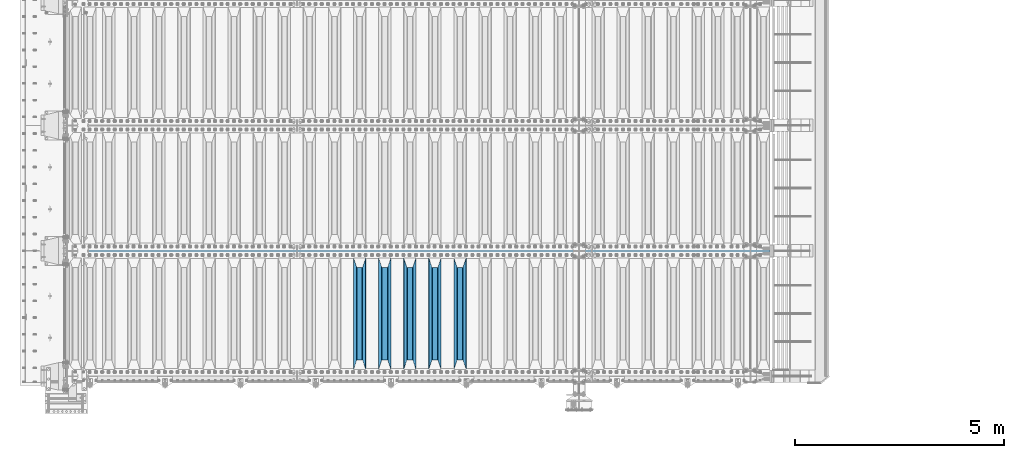
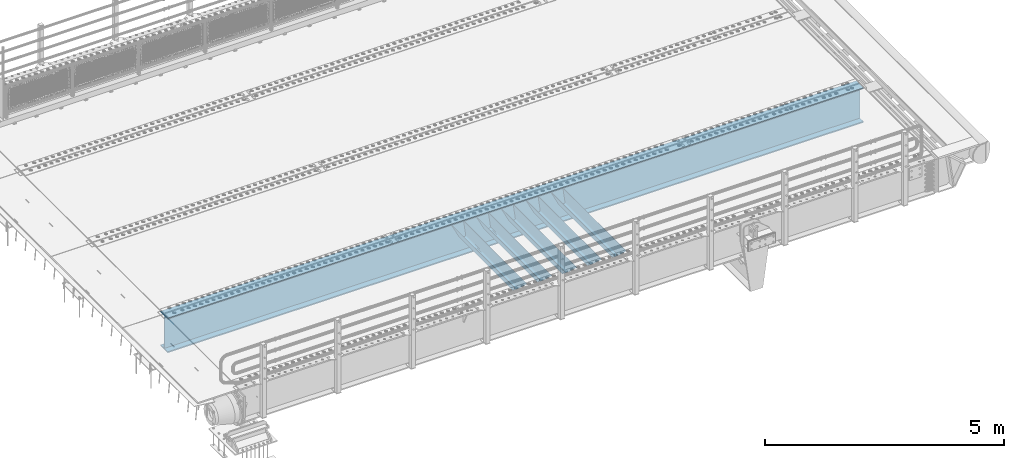
# One storey, part 107 of 257: 6 beams.
"""IFC2X3 building model written with IfcOpenShell, lengths in millimetres."""

from ifc_helpers import new_model, si_unit, frame, origin_with_axes, place, context, subcontext, project, spatial, faceted_brep, material, type_object, element, save


model = new_model("IFC2X3")

# Units and contexts
model_context = context("Model", 3, precision=1e-05, world=origin_with_axes())
body_context = subcontext(model_context, "Body", "Model", "MODEL_VIEW")
ifc_project = project(units=[si_unit("LENGTHUNIT", "METRE", prefix="MILLI"), si_unit("AREAUNIT", "SQUARE_METRE"), si_unit("VOLUMEUNIT", "CUBIC_METRE"), si_unit("MASSUNIT", "GRAM", prefix="KILO"), si_unit("TIMEUNIT", "SECOND"), si_unit("PLANEANGLEUNIT", "RADIAN"), si_unit("SOLIDANGLEUNIT", "STERADIAN"), si_unit("THERMODYNAMICTEMPERATUREUNIT", "DEGREE_CELSIUS"), si_unit("LUMINOUSINTENSITYUNIT", "LUMEN")], contexts=[model_context])

# Site, building, storey
site_placement = place(None, origin_with_axes())
site = spatial("IfcSite", under=ifc_project, at=site_placement, CompositionType="ELEMENT")
building_placement = place(site_placement, origin_with_axes())
building = spatial("IfcBuilding", under=site, at=building_placement, Name="Standard", CompositionType="ELEMENT")
storey_placement = place(building_placement, origin_with_axes())
storey = spatial("IfcBuildingStorey", under=building, at=storey_placement, Name="Undefined", CompositionType="ELEMENT", Elevation=0.0)

# Beams
ifc_material = material(Name="STEEL/S355N")
beam_type_1 = type_object("IfcBeamType", PredefinedType="NOTDEFINED")
beam_1_placement = place(storey_placement, frame((51850.0, 175.0, -115.0), z_axis=(0.0, 0.0, 1.0), x_axis=(0.0, 1.0, 0.0)))
element("IfcBeam", 1, at=beam_1_placement, inside=storey, type_object=beam_type_1, material=ifc_material, context=body_context, shape_type="Brep", body=[
    faceted_brep([(0.0, 150.0, 115.0), (0.0, 143.690000000002, 115.0), (2650.00000000297, 143.690000000002, 115.0), (2650.00000000297, 150.0, 115.0), (2650.00000000297, 142.059565218406, 110.0000000031), (2650.00000000297, 148.369565218403, 110.0000000031), (2441.90079219208, -80.1103600731149, -98.0992078077845), (2437.7588105432, -77.5672621345584, -102.241189456673), (2434.06523489746, -74.4080125315522, -105.934765102404), (2430.91086095089, -70.7102721255724, -109.089139048974), (2428.37322971128, -66.5649389910031, -111.626770288588), (2426.51472138055, -62.0739139532889, -113.485278619323), (2425.38102192091, -57.3475956567636, -114.618978078955), (2424.99999999987, -52.5021667386536, -115.0), (2424.99999999987, 52.5021667386536, -115.0), (2425.38102192091, 57.3475956567636, -114.618978078955), (2426.51472138055, 62.0739139532889, -113.485278619323), (2428.37322971128, 66.5649389910031, -111.626770288588), (2430.91086095089, 70.7102721255724, -109.089139048974), (2434.06523489746, 74.4080125315522, -105.934765102404), (2437.7588105432, 77.5672621345584, -102.241189456673), (2441.90079219208, 80.1103600731149, -98.0992078077846), (2446.38936140511, 81.9747917625791, -93.6106385947584), (2448.24948500409, 76.2713538057287, -91.7505149957729), (2444.62967112262, 74.76777986261, -95.3703288772456), (2441.28936334126, 72.7168944282894, -98.710636658607), (2438.31067330438, 70.1691124903809, -101.689326695487), (2435.76682334747, 67.1870637758839, -104.233176652398), (2433.72034654133, 63.8440531834931, -106.279653458539), (2432.22154950041, 60.2222587982324, -107.778450499454), (2431.30727574265, 56.4107117849126, -108.692724257221), (2430.99999999987, 52.5031078186876, -109.0), (2430.99999999987, -52.5031078186876, -109.0), (2431.30727574265, -56.4107117849126, -108.692724257221), (2432.22154950041, -60.2222587982324, -107.778450499454), (2433.72034654133, -63.8440531834931, -106.279653458539), (2435.76682334747, -67.1870637758839, -104.233176652398), (2438.31067330438, -70.1691124903809, -101.689326695487), (2441.28936334126, -72.7168944282894, -98.7106366586071), (2444.62967112262, -74.76777986261, -95.3703288772457), (2448.24948500409, -76.2713538057287, -91.7505149957729), (2650.00000000297, -142.059565218406, 110.0000000031), (2650.00000000297, -148.369565218403, 110.0000000031), (2446.38936140511, -81.9747917625791, -93.6106385947584), (2650.00000000297, -143.690000000002, 115.0), (2650.00000000297, -150.0, 115.0), (0.0, -143.690000000002, 115.0), (0.0, -150.0, 115.0), (0.0, -148.369565218258, 110.000000002662), (203.61063859742, -81.9747917625791, -93.6106385947584), (208.099207810447, -80.1103600731149, -98.0992078077845), (212.241189459335, -77.5672621345584, -102.241189456673), (215.934765105066, -74.4080125315522, -105.934765102404), (219.089139051636, -70.7102721255724, -109.089139048974), (221.626770291251, -66.5649389910031, -111.626770288588), (223.485278621985, -62.0739139532889, -113.485278619323), (224.618978081617, -57.3475956567636, -114.618978078955), (225.000000002662, -52.5021667386536, -115.0), (225.000000002662, 52.5021667386536, -115.0), (224.618978081617, 57.3475956567636, -114.618978078955), (223.485278621985, 62.0739139532889, -113.485278619323), (221.626770291251, 66.5649389910031, -111.626770288588), (219.089139051636, 70.7102721255724, -109.089139048974), (215.934765105066, 74.4080125315522, -105.934765102404), (212.241189459335, 77.5672621345584, -102.241189456673), (208.099207810447, 80.1103600731149, -98.0992078077846), (203.61063859742, 81.9747917625791, -93.6106385947584), (0.0, 148.369565218258, 110.000000002662), (0.0, 142.05956521826, 110.000000002662), (201.750514998435, 76.2713538057287, -91.7505149957729), (205.370328879908, 74.76777986261, -95.3703288772456), (208.710636661269, 72.7168944282894, -98.710636658607), (211.689326698149, 70.1691124903809, -101.689326695487), (214.233176655061, 67.1870637758839, -104.233176652398), (216.279653461201, 63.8440531834931, -106.279653458539), (217.778450502116, 60.2222587982324, -107.778450499454), (218.692724259884, 56.4107117849126, -108.692724257221), (219.000000002662, 52.5031078186876, -109.0), (219.000000002662, -52.5031078186876, -109.0), (218.692724259884, -56.4107117849126, -108.692724257221), (217.778450502116, -60.2222587982324, -107.778450499454), (216.279653461201, -63.8440531834931, -106.279653458539), (214.233176655061, -67.1870637758839, -104.233176652398), (211.689326698149, -70.1691124903809, -101.689326695487), (208.710636661269, -72.7168944282894, -98.7106366586071), (205.370328879908, -74.76777986261, -95.3703288772457), (201.750514998435, -76.2713538057287, -91.7505149957729), (0.0, -142.05956521826, 110.000000002662)], [[[0, 1, 2, 3]], [[3, 2, 4, 5]], [[6, 7, 8, 9, 10, 11, 12, 13, 14, 15, 16, 17, 18, 19, 20, 21, 22, 5, 4, 23, 24, 25, 26, 27, 28, 29, 30, 31, 32, 33, 34, 35, 36, 37, 38, 39, 40, 41, 42, 43]], [[44, 45, 42, 41]], [[46, 47, 45, 44]], [[43, 42, 45, 47, 48, 49]], [[6, 43, 49, 50]], [[7, 6, 50, 51]], [[8, 7, 51, 52]], [[9, 8, 52, 53]], [[10, 9, 53, 54]], [[11, 10, 54, 55]], [[12, 11, 55, 56]], [[13, 12, 56, 57]], [[14, 13, 57, 58]], [[15, 14, 58, 59]], [[16, 15, 59, 60]], [[17, 16, 60, 61]], [[18, 17, 61, 62]], [[19, 18, 62, 63]], [[20, 19, 63, 64]], [[21, 20, 64, 65]], [[22, 21, 65, 66]], [[0, 3, 5, 22, 66, 67]], [[1, 0, 67, 68]], [[23, 4, 2, 1, 68, 69]], [[24, 23, 69, 70]], [[25, 24, 70, 71]], [[26, 25, 71, 72]], [[27, 26, 72, 73]], [[28, 27, 73, 74]], [[29, 28, 74, 75]], [[30, 29, 75, 76]], [[31, 30, 76, 77]], [[32, 31, 77, 78]], [[33, 32, 78, 79]], [[34, 33, 79, 80]], [[35, 34, 80, 81]], [[36, 35, 81, 82]], [[37, 36, 82, 83]], [[38, 37, 83, 84]], [[39, 38, 84, 85]], [[40, 39, 85, 86]], [[46, 44, 41, 40, 86, 87]], [[47, 46, 87, 48]], [[86, 85, 84, 83, 82, 81, 80, 79, 78, 77, 76, 75, 74, 73, 72, 71, 70, 69, 68, 67, 66, 65, 64, 63, 62, 61, 60, 59, 58, 57, 56, 55, 54, 53, 52, 51, 50, 49, 48, 87]]]),
])
beam_2_placement = place(storey_placement, frame((51250.0, 175.0, -115.0), z_axis=(0.0, 0.0, 1.0), x_axis=(0.0, 1.0, 0.0)))
element("IfcBeam", 2, at=beam_2_placement, inside=storey, type_object=beam_type_1, material=ifc_material, context=body_context, shape_type="Brep", body=[
    faceted_brep([(0.0, 150.0, 115.0), (0.0, 143.690000000002, 115.0), (2650.00000000297, 143.690000000002, 115.0), (2650.00000000297, 150.0, 115.0), (2650.00000000297, 142.059565218406, 110.0000000031), (2650.00000000297, 148.369565218403, 110.0000000031), (2441.90079219208, -80.1103600731149, -98.0992078077845), (2437.7588105432, -77.5672621345584, -102.241189456673), (2434.06523489746, -74.4080125315522, -105.934765102404), (2430.91086095089, -70.7102721255724, -109.089139048974), (2428.37322971128, -66.5649389910031, -111.626770288588), (2426.51472138055, -62.0739139532889, -113.485278619323), (2425.38102192091, -57.3475956567636, -114.618978078955), (2424.99999999987, -52.5021667386536, -115.0), (2424.99999999987, 52.5021667386536, -115.0), (2425.38102192091, 57.3475956567636, -114.618978078955), (2426.51472138055, 62.0739139532889, -113.485278619323), (2428.37322971128, 66.5649389910031, -111.626770288588), (2430.91086095089, 70.7102721255724, -109.089139048974), (2434.06523489746, 74.4080125315522, -105.934765102404), (2437.7588105432, 77.5672621345584, -102.241189456673), (2441.90079219208, 80.1103600731149, -98.0992078077846), (2446.38936140511, 81.9747917625791, -93.6106385947584), (2448.24948500409, 76.2713538057287, -91.7505149957729), (2444.62967112262, 74.76777986261, -95.3703288772456), (2441.28936334126, 72.7168944282894, -98.710636658607), (2438.31067330438, 70.1691124903809, -101.689326695487), (2435.76682334747, 67.1870637758839, -104.233176652398), (2433.72034654133, 63.8440531834931, -106.279653458539), (2432.22154950041, 60.2222587982324, -107.778450499454), (2431.30727574265, 56.4107117849126, -108.692724257221), (2430.99999999987, 52.5031078186876, -109.0), (2430.99999999987, -52.5031078186876, -109.0), (2431.30727574265, -56.4107117849126, -108.692724257221), (2432.22154950041, -60.2222587982324, -107.778450499454), (2433.72034654133, -63.8440531834931, -106.279653458539), (2435.76682334747, -67.1870637758839, -104.233176652398), (2438.31067330438, -70.1691124903809, -101.689326695487), (2441.28936334126, -72.7168944282894, -98.7106366586071), (2444.62967112262, -74.76777986261, -95.3703288772457), (2448.24948500409, -76.2713538057287, -91.7505149957729), (2650.00000000297, -142.059565218406, 110.0000000031), (2650.00000000297, -148.369565218403, 110.0000000031), (2446.38936140511, -81.9747917625791, -93.6106385947584), (2650.00000000297, -143.690000000002, 115.0), (2650.00000000297, -150.0, 115.0), (0.0, -143.690000000002, 115.0), (0.0, -150.0, 115.0), (0.0, -148.369565218258, 110.000000002662), (203.61063859742, -81.9747917625791, -93.6106385947584), (208.099207810447, -80.1103600731149, -98.0992078077845), (212.241189459335, -77.5672621345584, -102.241189456673), (215.934765105066, -74.4080125315522, -105.934765102404), (219.089139051636, -70.7102721255724, -109.089139048974), (221.626770291251, -66.5649389910031, -111.626770288588), (223.485278621985, -62.0739139532889, -113.485278619323), (224.618978081617, -57.3475956567636, -114.618978078955), (225.000000002662, -52.5021667386536, -115.0), (225.000000002662, 52.5021667386536, -115.0), (224.618978081617, 57.3475956567636, -114.618978078955), (223.485278621985, 62.0739139532889, -113.485278619323), (221.626770291251, 66.5649389910031, -111.626770288588), (219.089139051636, 70.7102721255724, -109.089139048974), (215.934765105066, 74.4080125315522, -105.934765102404), (212.241189459335, 77.5672621345584, -102.241189456673), (208.099207810447, 80.1103600731149, -98.0992078077846), (203.61063859742, 81.9747917625791, -93.6106385947584), (0.0, 148.369565218258, 110.000000002662), (0.0, 142.05956521826, 110.000000002662), (201.750514998435, 76.2713538057287, -91.7505149957729), (205.370328879908, 74.76777986261, -95.3703288772456), (208.710636661269, 72.7168944282894, -98.710636658607), (211.689326698149, 70.1691124903809, -101.689326695487), (214.233176655061, 67.1870637758839, -104.233176652398), (216.279653461201, 63.8440531834931, -106.279653458539), (217.778450502116, 60.2222587982324, -107.778450499454), (218.692724259884, 56.4107117849126, -108.692724257221), (219.000000002662, 52.5031078186876, -109.0), (219.000000002662, -52.5031078186876, -109.0), (218.692724259884, -56.4107117849126, -108.692724257221), (217.778450502116, -60.2222587982324, -107.778450499454), (216.279653461201, -63.8440531834931, -106.279653458539), (214.233176655061, -67.1870637758839, -104.233176652398), (211.689326698149, -70.1691124903809, -101.689326695487), (208.710636661269, -72.7168944282894, -98.7106366586071), (205.370328879908, -74.76777986261, -95.3703288772457), (201.750514998435, -76.2713538057287, -91.7505149957729), (0.0, -142.05956521826, 110.000000002662)], [[[0, 1, 2, 3]], [[3, 2, 4, 5]], [[6, 7, 8, 9, 10, 11, 12, 13, 14, 15, 16, 17, 18, 19, 20, 21, 22, 5, 4, 23, 24, 25, 26, 27, 28, 29, 30, 31, 32, 33, 34, 35, 36, 37, 38, 39, 40, 41, 42, 43]], [[44, 45, 42, 41]], [[46, 47, 45, 44]], [[43, 42, 45, 47, 48, 49]], [[6, 43, 49, 50]], [[7, 6, 50, 51]], [[8, 7, 51, 52]], [[9, 8, 52, 53]], [[10, 9, 53, 54]], [[11, 10, 54, 55]], [[12, 11, 55, 56]], [[13, 12, 56, 57]], [[14, 13, 57, 58]], [[15, 14, 58, 59]], [[16, 15, 59, 60]], [[17, 16, 60, 61]], [[18, 17, 61, 62]], [[19, 18, 62, 63]], [[20, 19, 63, 64]], [[21, 20, 64, 65]], [[22, 21, 65, 66]], [[0, 3, 5, 22, 66, 67]], [[1, 0, 67, 68]], [[23, 4, 2, 1, 68, 69]], [[24, 23, 69, 70]], [[25, 24, 70, 71]], [[26, 25, 71, 72]], [[27, 26, 72, 73]], [[28, 27, 73, 74]], [[29, 28, 74, 75]], [[30, 29, 75, 76]], [[31, 30, 76, 77]], [[32, 31, 77, 78]], [[33, 32, 78, 79]], [[34, 33, 79, 80]], [[35, 34, 80, 81]], [[36, 35, 81, 82]], [[37, 36, 82, 83]], [[38, 37, 83, 84]], [[39, 38, 84, 85]], [[40, 39, 85, 86]], [[46, 44, 41, 40, 86, 87]], [[47, 46, 87, 48]], [[86, 85, 84, 83, 82, 81, 80, 79, 78, 77, 76, 75, 74, 73, 72, 71, 70, 69, 68, 67, 66, 65, 64, 63, 62, 61, 60, 59, 58, 57, 56, 55, 54, 53, 52, 51, 50, 49, 48, 87]]]),
])
beam_3_placement = place(storey_placement, frame((50650.0, 175.0, -115.0), z_axis=(0.0, 0.0, 1.0), x_axis=(0.0, 1.0, 0.0)))
element("IfcBeam", 3, at=beam_3_placement, inside=storey, type_object=beam_type_1, material=ifc_material, context=body_context, shape_type="Brep", body=[
    faceted_brep([(0.0, 150.0, 115.0), (0.0, 143.690000000002, 115.0), (2650.00000000297, 143.690000000002, 115.0), (2650.00000000297, 150.0, 115.0), (2650.00000000297, 142.059565218406, 110.0000000031), (2650.00000000297, 148.369565218403, 110.0000000031), (2441.90079219208, -80.1103600731149, -98.0992078077845), (2437.7588105432, -77.5672621345584, -102.241189456673), (2434.06523489746, -74.4080125315522, -105.934765102404), (2430.91086095089, -70.7102721255724, -109.089139048974), (2428.37322971128, -66.5649389910031, -111.626770288588), (2426.51472138055, -62.0739139532889, -113.485278619323), (2425.38102192091, -57.3475956567636, -114.618978078955), (2424.99999999987, -52.5021667386536, -115.0), (2424.99999999987, 52.5021667386536, -115.0), (2425.38102192091, 57.3475956567636, -114.618978078955), (2426.51472138055, 62.0739139532889, -113.485278619323), (2428.37322971128, 66.5649389910031, -111.626770288588), (2430.91086095089, 70.7102721255724, -109.089139048974), (2434.06523489746, 74.4080125315522, -105.934765102404), (2437.7588105432, 77.5672621345584, -102.241189456673), (2441.90079219208, 80.1103600731149, -98.0992078077846), (2446.38936140511, 81.9747917625791, -93.6106385947584), (2448.24948500409, 76.2713538057287, -91.7505149957729), (2444.62967112262, 74.76777986261, -95.3703288772456), (2441.28936334126, 72.7168944282894, -98.710636658607), (2438.31067330438, 70.1691124903809, -101.689326695487), (2435.76682334747, 67.1870637758839, -104.233176652398), (2433.72034654133, 63.8440531834931, -106.279653458539), (2432.22154950041, 60.2222587982324, -107.778450499454), (2431.30727574265, 56.4107117849126, -108.692724257221), (2430.99999999987, 52.5031078186876, -109.0), (2430.99999999987, -52.5031078186876, -109.0), (2431.30727574265, -56.4107117849126, -108.692724257221), (2432.22154950041, -60.2222587982324, -107.778450499454), (2433.72034654133, -63.8440531834931, -106.279653458539), (2435.76682334747, -67.1870637758839, -104.233176652398), (2438.31067330438, -70.1691124903809, -101.689326695487), (2441.28936334126, -72.7168944282894, -98.7106366586071), (2444.62967112262, -74.76777986261, -95.3703288772457), (2448.24948500409, -76.2713538057287, -91.7505149957729), (2650.00000000297, -142.059565218406, 110.0000000031), (2650.00000000297, -148.369565218403, 110.0000000031), (2446.38936140511, -81.9747917625791, -93.6106385947584), (2650.00000000297, -143.690000000002, 115.0), (2650.00000000297, -150.0, 115.0), (0.0, -143.690000000002, 115.0), (0.0, -150.0, 115.0), (0.0, -148.369565218258, 110.000000002662), (203.61063859742, -81.9747917625791, -93.6106385947584), (208.099207810447, -80.1103600731149, -98.0992078077845), (212.241189459335, -77.5672621345584, -102.241189456673), (215.934765105066, -74.4080125315522, -105.934765102404), (219.089139051636, -70.7102721255724, -109.089139048974), (221.626770291251, -66.5649389910031, -111.626770288588), (223.485278621985, -62.0739139532889, -113.485278619323), (224.618978081617, -57.3475956567636, -114.618978078955), (225.000000002662, -52.5021667386536, -115.0), (225.000000002662, 52.5021667386536, -115.0), (224.618978081617, 57.3475956567636, -114.618978078955), (223.485278621985, 62.0739139532889, -113.485278619323), (221.626770291251, 66.5649389910031, -111.626770288588), (219.089139051636, 70.7102721255724, -109.089139048974), (215.934765105066, 74.4080125315522, -105.934765102404), (212.241189459335, 77.5672621345584, -102.241189456673), (208.099207810447, 80.1103600731149, -98.0992078077846), (203.61063859742, 81.9747917625791, -93.6106385947584), (0.0, 148.369565218258, 110.000000002662), (0.0, 142.05956521826, 110.000000002662), (201.750514998435, 76.2713538057287, -91.7505149957729), (205.370328879908, 74.76777986261, -95.3703288772456), (208.710636661269, 72.7168944282894, -98.710636658607), (211.689326698149, 70.1691124903809, -101.689326695487), (214.233176655061, 67.1870637758839, -104.233176652398), (216.279653461201, 63.8440531834931, -106.279653458539), (217.778450502116, 60.2222587982324, -107.778450499454), (218.692724259884, 56.4107117849126, -108.692724257221), (219.000000002662, 52.5031078186876, -109.0), (219.000000002662, -52.5031078186876, -109.0), (218.692724259884, -56.4107117849126, -108.692724257221), (217.778450502116, -60.2222587982324, -107.778450499454), (216.279653461201, -63.8440531834931, -106.279653458539), (214.233176655061, -67.1870637758839, -104.233176652398), (211.689326698149, -70.1691124903809, -101.689326695487), (208.710636661269, -72.7168944282894, -98.7106366586071), (205.370328879908, -74.76777986261, -95.3703288772457), (201.750514998435, -76.2713538057287, -91.7505149957729), (0.0, -142.05956521826, 110.000000002662)], [[[0, 1, 2, 3]], [[3, 2, 4, 5]], [[6, 7, 8, 9, 10, 11, 12, 13, 14, 15, 16, 17, 18, 19, 20, 21, 22, 5, 4, 23, 24, 25, 26, 27, 28, 29, 30, 31, 32, 33, 34, 35, 36, 37, 38, 39, 40, 41, 42, 43]], [[44, 45, 42, 41]], [[46, 47, 45, 44]], [[43, 42, 45, 47, 48, 49]], [[6, 43, 49, 50]], [[7, 6, 50, 51]], [[8, 7, 51, 52]], [[9, 8, 52, 53]], [[10, 9, 53, 54]], [[11, 10, 54, 55]], [[12, 11, 55, 56]], [[13, 12, 56, 57]], [[14, 13, 57, 58]], [[15, 14, 58, 59]], [[16, 15, 59, 60]], [[17, 16, 60, 61]], [[18, 17, 61, 62]], [[19, 18, 62, 63]], [[20, 19, 63, 64]], [[21, 20, 64, 65]], [[22, 21, 65, 66]], [[0, 3, 5, 22, 66, 67]], [[1, 0, 67, 68]], [[23, 4, 2, 1, 68, 69]], [[24, 23, 69, 70]], [[25, 24, 70, 71]], [[26, 25, 71, 72]], [[27, 26, 72, 73]], [[28, 27, 73, 74]], [[29, 28, 74, 75]], [[30, 29, 75, 76]], [[31, 30, 76, 77]], [[32, 31, 77, 78]], [[33, 32, 78, 79]], [[34, 33, 79, 80]], [[35, 34, 80, 81]], [[36, 35, 81, 82]], [[37, 36, 82, 83]], [[38, 37, 83, 84]], [[39, 38, 84, 85]], [[40, 39, 85, 86]], [[46, 44, 41, 40, 86, 87]], [[47, 46, 87, 48]], [[86, 85, 84, 83, 82, 81, 80, 79, 78, 77, 76, 75, 74, 73, 72, 71, 70, 69, 68, 67, 66, 65, 64, 63, 62, 61, 60, 59, 58, 57, 56, 55, 54, 53, 52, 51, 50, 49, 48, 87]]]),
])
beam_4_placement = place(storey_placement, frame((50050.0, 175.0, -115.0), z_axis=(0.0, 0.0, 1.0), x_axis=(0.0, 1.0, 0.0)))
element("IfcBeam", 4, at=beam_4_placement, inside=storey, type_object=beam_type_1, material=ifc_material, context=body_context, shape_type="Brep", body=[
    faceted_brep([(0.0, 150.0, 115.0), (0.0, 143.690000000002, 115.0), (2650.00000000297, 143.690000000002, 115.0), (2650.00000000297, 150.0, 115.0), (2650.00000000297, 142.059565218406, 110.0000000031), (2650.00000000297, 148.369565218403, 110.0000000031), (2441.90079219208, -80.1103600731149, -98.0992078077845), (2437.7588105432, -77.5672621345584, -102.241189456673), (2434.06523489746, -74.4080125315522, -105.934765102404), (2430.91086095089, -70.7102721255724, -109.089139048974), (2428.37322971128, -66.5649389910031, -111.626770288588), (2426.51472138055, -62.0739139532889, -113.485278619323), (2425.38102192091, -57.3475956567636, -114.618978078955), (2424.99999999987, -52.5021667386536, -115.0), (2424.99999999987, 52.5021667386536, -115.0), (2425.38102192091, 57.3475956567636, -114.618978078955), (2426.51472138055, 62.0739139532889, -113.485278619323), (2428.37322971128, 66.5649389910031, -111.626770288588), (2430.91086095089, 70.7102721255724, -109.089139048974), (2434.06523489746, 74.4080125315522, -105.934765102404), (2437.7588105432, 77.5672621345584, -102.241189456673), (2441.90079219208, 80.1103600731149, -98.0992078077846), (2446.38936140511, 81.9747917625791, -93.6106385947584), (2448.24948500409, 76.2713538057287, -91.7505149957729), (2444.62967112262, 74.76777986261, -95.3703288772456), (2441.28936334126, 72.7168944282894, -98.710636658607), (2438.31067330438, 70.1691124903809, -101.689326695487), (2435.76682334747, 67.1870637758839, -104.233176652398), (2433.72034654133, 63.8440531834931, -106.279653458539), (2432.22154950041, 60.2222587982324, -107.778450499454), (2431.30727574265, 56.4107117849126, -108.692724257221), (2430.99999999987, 52.5031078186876, -109.0), (2430.99999999987, -52.5031078186876, -109.0), (2431.30727574265, -56.4107117849126, -108.692724257221), (2432.22154950041, -60.2222587982324, -107.778450499454), (2433.72034654133, -63.8440531834931, -106.279653458539), (2435.76682334747, -67.1870637758839, -104.233176652398), (2438.31067330438, -70.1691124903809, -101.689326695487), (2441.28936334126, -72.7168944282894, -98.7106366586071), (2444.62967112262, -74.76777986261, -95.3703288772457), (2448.24948500409, -76.2713538057287, -91.7505149957729), (2650.00000000297, -142.059565218406, 110.0000000031), (2650.00000000297, -148.369565218403, 110.0000000031), (2446.38936140511, -81.9747917625791, -93.6106385947584), (2650.00000000297, -143.690000000002, 115.0), (2650.00000000297, -150.0, 115.0), (0.0, -143.690000000002, 115.0), (0.0, -150.0, 115.0), (0.0, -148.369565218258, 110.000000002662), (203.61063859742, -81.9747917625791, -93.6106385947584), (208.099207810447, -80.1103600731149, -98.0992078077845), (212.241189459335, -77.5672621345584, -102.241189456673), (215.934765105066, -74.4080125315522, -105.934765102404), (219.089139051636, -70.7102721255724, -109.089139048974), (221.626770291251, -66.5649389910031, -111.626770288588), (223.485278621985, -62.0739139532889, -113.485278619323), (224.618978081617, -57.3475956567636, -114.618978078955), (225.000000002662, -52.5021667386536, -115.0), (225.000000002662, 52.5021667386536, -115.0), (224.618978081617, 57.3475956567636, -114.618978078955), (223.485278621985, 62.0739139532889, -113.485278619323), (221.626770291251, 66.5649389910031, -111.626770288588), (219.089139051636, 70.7102721255724, -109.089139048974), (215.934765105066, 74.4080125315522, -105.934765102404), (212.241189459335, 77.5672621345584, -102.241189456673), (208.099207810447, 80.1103600731149, -98.0992078077846), (203.61063859742, 81.9747917625791, -93.6106385947584), (0.0, 148.369565218258, 110.000000002662), (0.0, 142.05956521826, 110.000000002662), (201.750514998435, 76.2713538057287, -91.7505149957729), (205.370328879908, 74.76777986261, -95.3703288772456), (208.710636661269, 72.7168944282894, -98.710636658607), (211.689326698149, 70.1691124903809, -101.689326695487), (214.233176655061, 67.1870637758839, -104.233176652398), (216.279653461201, 63.8440531834931, -106.279653458539), (217.778450502116, 60.2222587982324, -107.778450499454), (218.692724259884, 56.4107117849126, -108.692724257221), (219.000000002662, 52.5031078186876, -109.0), (219.000000002662, -52.5031078186876, -109.0), (218.692724259884, -56.4107117849126, -108.692724257221), (217.778450502116, -60.2222587982324, -107.778450499454), (216.279653461201, -63.8440531834931, -106.279653458539), (214.233176655061, -67.1870637758839, -104.233176652398), (211.689326698149, -70.1691124903809, -101.689326695487), (208.710636661269, -72.7168944282894, -98.7106366586071), (205.370328879908, -74.76777986261, -95.3703288772457), (201.750514998435, -76.2713538057287, -91.7505149957729), (0.0, -142.05956521826, 110.000000002662)], [[[0, 1, 2, 3]], [[3, 2, 4, 5]], [[6, 7, 8, 9, 10, 11, 12, 13, 14, 15, 16, 17, 18, 19, 20, 21, 22, 5, 4, 23, 24, 25, 26, 27, 28, 29, 30, 31, 32, 33, 34, 35, 36, 37, 38, 39, 40, 41, 42, 43]], [[44, 45, 42, 41]], [[46, 47, 45, 44]], [[43, 42, 45, 47, 48, 49]], [[6, 43, 49, 50]], [[7, 6, 50, 51]], [[8, 7, 51, 52]], [[9, 8, 52, 53]], [[10, 9, 53, 54]], [[11, 10, 54, 55]], [[12, 11, 55, 56]], [[13, 12, 56, 57]], [[14, 13, 57, 58]], [[15, 14, 58, 59]], [[16, 15, 59, 60]], [[17, 16, 60, 61]], [[18, 17, 61, 62]], [[19, 18, 62, 63]], [[20, 19, 63, 64]], [[21, 20, 64, 65]], [[22, 21, 65, 66]], [[0, 3, 5, 22, 66, 67]], [[1, 0, 67, 68]], [[23, 4, 2, 1, 68, 69]], [[24, 23, 69, 70]], [[25, 24, 70, 71]], [[26, 25, 71, 72]], [[27, 26, 72, 73]], [[28, 27, 73, 74]], [[29, 28, 74, 75]], [[30, 29, 75, 76]], [[31, 30, 76, 77]], [[32, 31, 77, 78]], [[33, 32, 78, 79]], [[34, 33, 79, 80]], [[35, 34, 80, 81]], [[36, 35, 81, 82]], [[37, 36, 82, 83]], [[38, 37, 83, 84]], [[39, 38, 84, 85]], [[40, 39, 85, 86]], [[46, 44, 41, 40, 86, 87]], [[47, 46, 87, 48]], [[86, 85, 84, 83, 82, 81, 80, 79, 78, 77, 76, 75, 74, 73, 72, 71, 70, 69, 68, 67, 66, 65, 64, 63, 62, 61, 60, 59, 58, 57, 56, 55, 54, 53, 52, 51, 50, 49, 48, 87]]]),
])
beam_5_placement = place(storey_placement, frame((49450.0, 175.0, -115.0), z_axis=(0.0, 0.0, 1.0), x_axis=(0.0, 1.0, 0.0)))
element("IfcBeam", 5, at=beam_5_placement, inside=storey, type_object=beam_type_1, material=ifc_material, context=body_context, shape_type="Brep", body=[
    faceted_brep([(0.0, 150.0, 115.0), (0.0, 143.690000000002, 115.0), (2650.00000000297, 143.690000000002, 115.0), (2650.00000000297, 150.0, 115.0), (2650.00000000297, 142.059565218406, 110.0000000031), (2650.00000000297, 148.369565218403, 110.0000000031), (2441.90079219208, -80.1103600731149, -98.0992078077845), (2437.7588105432, -77.5672621345584, -102.241189456673), (2434.06523489746, -74.4080125315522, -105.934765102404), (2430.91086095089, -70.7102721255724, -109.089139048974), (2428.37322971128, -66.5649389910031, -111.626770288588), (2426.51472138055, -62.0739139532889, -113.485278619323), (2425.38102192091, -57.3475956567636, -114.618978078955), (2424.99999999987, -52.5021667386536, -115.0), (2424.99999999987, 52.5021667386536, -115.0), (2425.38102192091, 57.3475956567636, -114.618978078955), (2426.51472138055, 62.0739139532889, -113.485278619323), (2428.37322971128, 66.5649389910031, -111.626770288588), (2430.91086095089, 70.7102721255724, -109.089139048974), (2434.06523489746, 74.4080125315522, -105.934765102404), (2437.7588105432, 77.5672621345584, -102.241189456673), (2441.90079219208, 80.1103600731149, -98.0992078077846), (2446.38936140511, 81.9747917625791, -93.6106385947584), (2448.24948500409, 76.2713538057287, -91.7505149957729), (2444.62967112262, 74.76777986261, -95.3703288772456), (2441.28936334126, 72.7168944282894, -98.710636658607), (2438.31067330438, 70.1691124903809, -101.689326695487), (2435.76682334747, 67.1870637758839, -104.233176652398), (2433.72034654133, 63.8440531834931, -106.279653458539), (2432.22154950041, 60.2222587982324, -107.778450499454), (2431.30727574265, 56.4107117849126, -108.692724257221), (2430.99999999987, 52.5031078186876, -109.0), (2430.99999999987, -52.5031078186876, -109.0), (2431.30727574265, -56.4107117849126, -108.692724257221), (2432.22154950041, -60.2222587982324, -107.778450499454), (2433.72034654133, -63.8440531834931, -106.279653458539), (2435.76682334747, -67.1870637758839, -104.233176652398), (2438.31067330438, -70.1691124903809, -101.689326695487), (2441.28936334126, -72.7168944282894, -98.7106366586071), (2444.62967112262, -74.76777986261, -95.3703288772457), (2448.24948500409, -76.2713538057287, -91.7505149957729), (2650.00000000297, -142.059565218406, 110.0000000031), (2650.00000000297, -148.369565218403, 110.0000000031), (2446.38936140511, -81.9747917625791, -93.6106385947584), (2650.00000000297, -143.690000000002, 115.0), (2650.00000000297, -150.0, 115.0), (0.0, -143.690000000002, 115.0), (0.0, -150.0, 115.0), (0.0, -148.369565218258, 110.000000002662), (203.61063859742, -81.9747917625791, -93.6106385947584), (208.099207810447, -80.1103600731149, -98.0992078077845), (212.241189459335, -77.5672621345584, -102.241189456673), (215.934765105066, -74.4080125315522, -105.934765102404), (219.089139051636, -70.7102721255724, -109.089139048974), (221.626770291251, -66.5649389910031, -111.626770288588), (223.485278621985, -62.0739139532889, -113.485278619323), (224.618978081617, -57.3475956567636, -114.618978078955), (225.000000002662, -52.5021667386536, -115.0), (225.000000002662, 52.5021667386536, -115.0), (224.618978081617, 57.3475956567636, -114.618978078955), (223.485278621985, 62.0739139532889, -113.485278619323), (221.626770291251, 66.5649389910031, -111.626770288588), (219.089139051636, 70.7102721255724, -109.089139048974), (215.934765105066, 74.4080125315522, -105.934765102404), (212.241189459335, 77.5672621345584, -102.241189456673), (208.099207810447, 80.1103600731149, -98.0992078077846), (203.61063859742, 81.9747917625791, -93.6106385947584), (0.0, 148.369565218258, 110.000000002662), (0.0, 142.05956521826, 110.000000002662), (201.750514998435, 76.2713538057287, -91.7505149957729), (205.370328879908, 74.76777986261, -95.3703288772456), (208.710636661269, 72.7168944282894, -98.710636658607), (211.689326698149, 70.1691124903809, -101.689326695487), (214.233176655061, 67.1870637758839, -104.233176652398), (216.279653461201, 63.8440531834931, -106.279653458539), (217.778450502116, 60.2222587982324, -107.778450499454), (218.692724259884, 56.4107117849126, -108.692724257221), (219.000000002662, 52.5031078186876, -109.0), (219.000000002662, -52.5031078186876, -109.0), (218.692724259884, -56.4107117849126, -108.692724257221), (217.778450502116, -60.2222587982324, -107.778450499454), (216.279653461201, -63.8440531834931, -106.279653458539), (214.233176655061, -67.1870637758839, -104.233176652398), (211.689326698149, -70.1691124903809, -101.689326695487), (208.710636661269, -72.7168944282894, -98.7106366586071), (205.370328879908, -74.76777986261, -95.3703288772457), (201.750514998435, -76.2713538057287, -91.7505149957729), (0.0, -142.05956521826, 110.000000002662)], [[[0, 1, 2, 3]], [[3, 2, 4, 5]], [[6, 7, 8, 9, 10, 11, 12, 13, 14, 15, 16, 17, 18, 19, 20, 21, 22, 5, 4, 23, 24, 25, 26, 27, 28, 29, 30, 31, 32, 33, 34, 35, 36, 37, 38, 39, 40, 41, 42, 43]], [[44, 45, 42, 41]], [[46, 47, 45, 44]], [[43, 42, 45, 47, 48, 49]], [[6, 43, 49, 50]], [[7, 6, 50, 51]], [[8, 7, 51, 52]], [[9, 8, 52, 53]], [[10, 9, 53, 54]], [[11, 10, 54, 55]], [[12, 11, 55, 56]], [[13, 12, 56, 57]], [[14, 13, 57, 58]], [[15, 14, 58, 59]], [[16, 15, 59, 60]], [[17, 16, 60, 61]], [[18, 17, 61, 62]], [[19, 18, 62, 63]], [[20, 19, 63, 64]], [[21, 20, 64, 65]], [[22, 21, 65, 66]], [[0, 3, 5, 22, 66, 67]], [[1, 0, 67, 68]], [[23, 4, 2, 1, 68, 69]], [[24, 23, 69, 70]], [[25, 24, 70, 71]], [[26, 25, 71, 72]], [[27, 26, 72, 73]], [[28, 27, 73, 74]], [[29, 28, 74, 75]], [[30, 29, 75, 76]], [[31, 30, 76, 77]], [[32, 31, 77, 78]], [[33, 32, 78, 79]], [[34, 33, 79, 80]], [[35, 34, 80, 81]], [[36, 35, 81, 82]], [[37, 36, 82, 83]], [[38, 37, 83, 84]], [[39, 38, 84, 85]], [[40, 39, 85, 86]], [[46, 44, 41, 40, 86, 87]], [[47, 46, 87, 48]], [[86, 85, 84, 83, 82, 81, 80, 79, 78, 77, 76, 75, 74, 73, 72, 71, 70, 69, 68, 67, 66, 65, 64, 63, 62, 61, 60, 59, 58, 57, 56, 55, 54, 53, 52, 51, 50, 49, 48, 87]]]),
])
beam_type_2 = type_object("IfcBeamType", Name="HEA900", PredefinedType="NOTDEFINED")
beam_6_placement = place(storey_placement, frame((42460.0, 3000.0, -445.0), z_axis=(0.0, 0.0, 1.0), x_axis=(1.0, 0.0, 0.0)))
element("IfcBeam", 6, at=beam_6_placement, inside=storey, type_object=beam_type_2, material=ifc_material, ObjectType="HEA900", context=body_context, shape_type="Brep", body=[
    faceted_brep([(0.0, 150.0, -445.0), (0.0, 150.0, -415.0), (16807.0, 150.0, -415.0), (16807.0, 150.0, -445.0), (0.0, 8.0, -415.0), (16807.0, 8.0, -415.0), (0.0, 8.0, 415.0), (16807.0, 8.0, 415.0), (0.0, 150.0, 415.0), (16807.0, 150.0, 415.0), (0.0, 150.0, 445.0), (16807.0, 150.0, 445.0), (0.0, -150.0, 445.0), (16807.0, -150.0, 445.0), (0.0, -150.0, 415.0), (16807.0, -150.0, 415.0), (0.0, -8.0, 415.0), (16807.0, -8.0, 415.0), (0.0, -8.0, -415.0), (16807.0, -8.0, -415.0), (0.0, -150.0, -415.0), (16807.0, -150.0, -415.0), (0.0, -150.0, -445.0), (16807.0, -150.0, -445.0)], [[[0, 1, 2, 3]], [[1, 4, 5, 2]], [[4, 6, 7, 5]], [[6, 8, 9, 7]], [[8, 10, 11, 9]], [[10, 12, 13, 11]], [[12, 14, 15, 13]], [[14, 16, 17, 15]], [[16, 18, 19, 17]], [[18, 20, 21, 19]], [[20, 22, 23, 21]], [[22, 0, 3, 23]], [[5, 7, 9, 11, 13, 15, 17, 19, 21, 23, 3, 2]], [[22, 20, 18, 16, 14, 12, 10, 8, 6, 4, 1, 0]]]),
])

save(model, "model.ifc")
